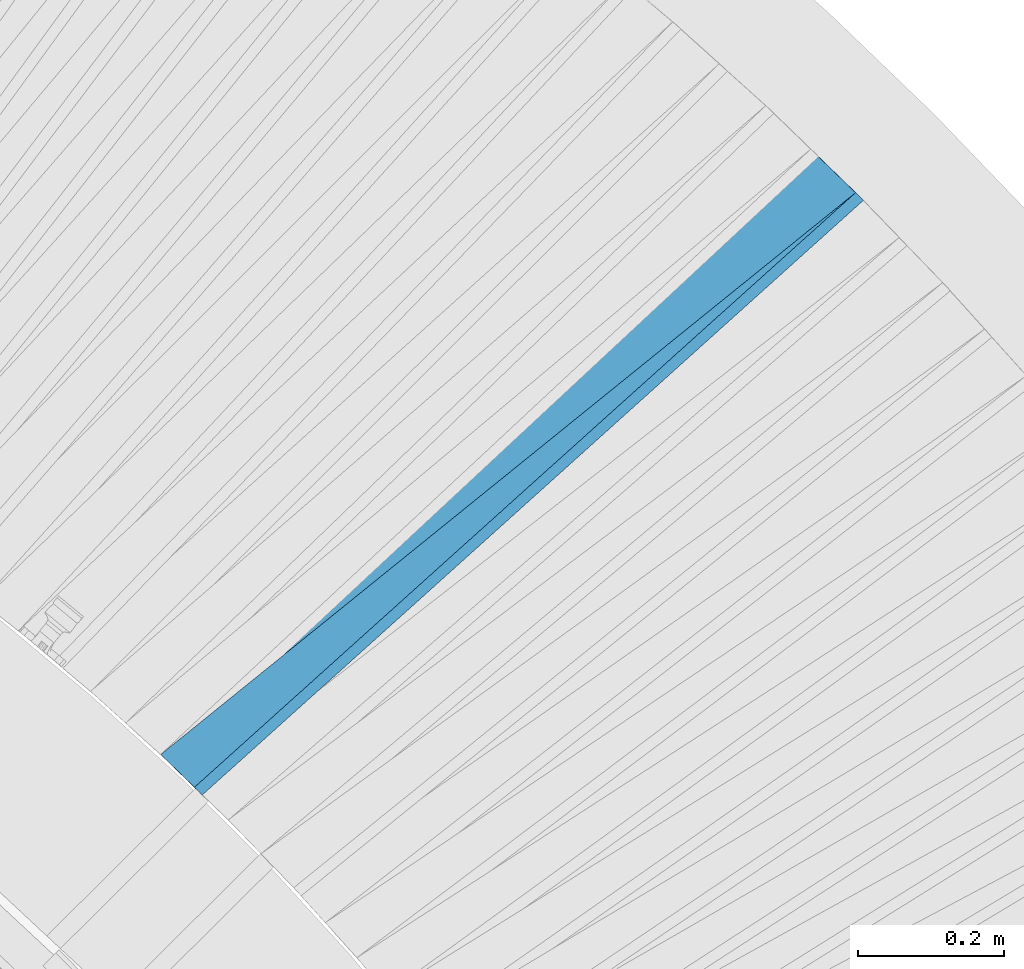
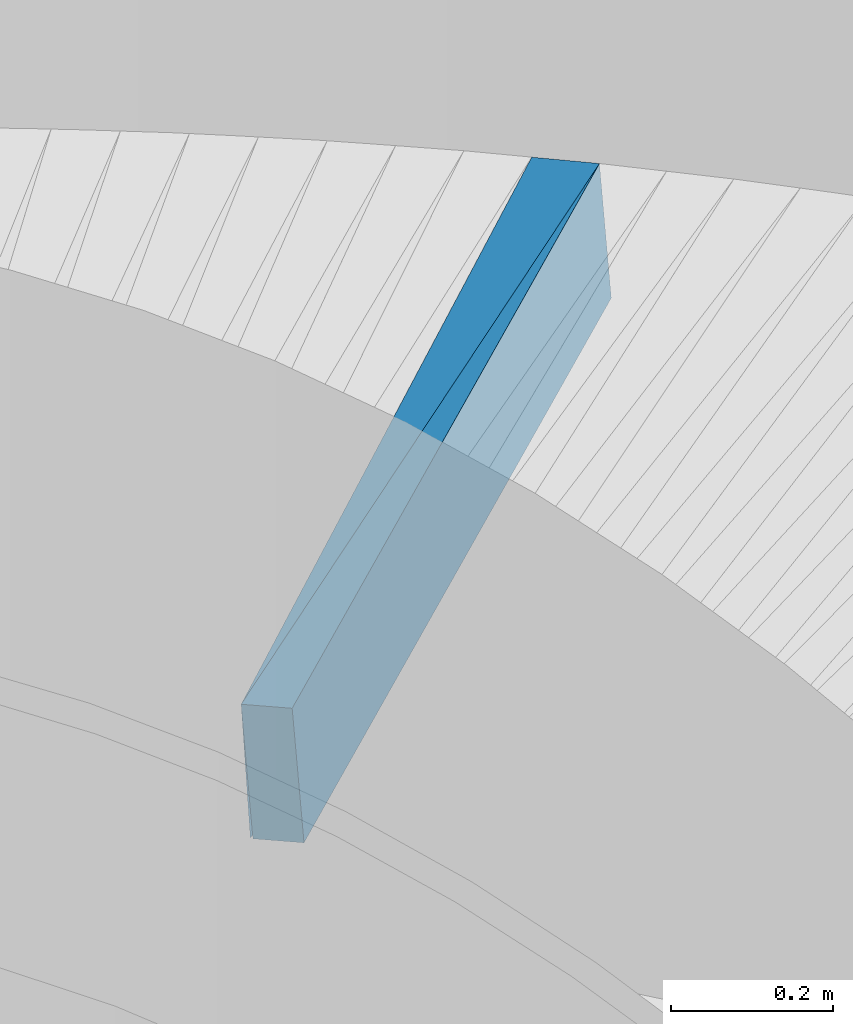
# One storey, part 841 of 975: 2 plates.
"""IFC2X3 building model written with IfcOpenShell, lengths in millimetres."""

from ifc_helpers import new_model, si_unit, frame, origin_with_axes, place, context, subcontext, project, spatial, faceted_brep, material, type_object, element, save


model = new_model("IFC2X3")

# Units and contexts
model_context = context("Model", 3, precision=1e-05, world=origin_with_axes())
body_context = subcontext(model_context, "Body", "Model", "MODEL_VIEW")
ifc_project = project(units=[si_unit("LENGTHUNIT", "METRE", prefix="MILLI"), si_unit("AREAUNIT", "SQUARE_METRE"), si_unit("VOLUMEUNIT", "CUBIC_METRE"), si_unit("MASSUNIT", "GRAM", prefix="KILO"), si_unit("TIMEUNIT", "SECOND"), si_unit("PLANEANGLEUNIT", "RADIAN"), si_unit("SOLIDANGLEUNIT", "STERADIAN"), si_unit("THERMODYNAMICTEMPERATUREUNIT", "DEGREE_CELSIUS"), si_unit("LUMINOUSINTENSITYUNIT", "LUMEN")], contexts=[model_context])

# Site, building, storey
site_placement = place(None, origin_with_axes())
site = spatial("IfcSite", under=ifc_project, at=site_placement, CompositionType="ELEMENT")
building_placement = place(site_placement, origin_with_axes())
building = spatial("IfcBuilding", under=site, at=building_placement, Name="Undefined", CompositionType="ELEMENT")
storey_placement = place(building_placement, origin_with_axes())
storey = spatial("IfcBuildingStorey", under=building, at=storey_placement, Name="Undefined", CompositionType="ELEMENT", Elevation=0.0)

# Plates
ifc_material = material(Name="STEEL/A36")
plate_type_1 = type_object("IfcPlateType", PredefinedType="NOTDEFINED")
plate_1_placement = place(storey_placement, frame((38161.2491672131, 6943.64217591275, 232.490790321188), z_axis=(0.680152573105857, -0.73077570815842, 0.0579598280107971), x_axis=(-0.731841587689349, -0.681462969710731, -0.00401390599829616)))
element("IfcPlate", 1, at=plate_1_placement, inside=storey, type_object=plate_type_1, material=ifc_material, Name="SLAB", context=body_context, shape_type="Brep", body=[
    faceted_brep([(-6.82121026329696e-12, -100.000000000011, -1.09139364212751e-10), (-4.56454038641095, -99.9999999999905, 85.9505386354322), (-4.56454038606898, 99.9999999999875, 85.9505386350502), (5.91171556152403e-12, 100.000000000011, 1.09139364212751e-10), (1220.75598144561, -99.9999999998736, 1.56433088704944e-09), (1220.75598144562, 100.000000000141, 1.74622982740402e-09)], [[[0, 1, 2, 3]], [[1, 4, 5, 2]], [[4, 0, 3, 5]], [[5, 3, 2]], [[4, 1, 0]]]),
])
plate_type_2 = type_object("IfcPlateType", PredefinedType="NOTDEFINED")
plate_2_placement = place(storey_placement, frame((38224.1464868164, 6882.58332052111, 237.606795995501), z_axis=(0.626437168463045, -0.775855096787258, 0.0750022850134328), x_axis=(-0.777640336801435, -0.628657734839477, -0.00805971499794202)))
element("IfcPlate", 2, at=plate_2_placement, inside=storey, type_object=plate_type_2, material=ifc_material, Name="SLAB", context=body_context, shape_type="Brep", body=[
    faceted_brep([(-6.82121026329696e-12, -100.000000000011, -1.09139364212751e-10), (1220.34338379136, -100.000000000173, 64.4729614234857), (1220.34338379146, 99.9999999998151, 64.4729614233802), (5.91171556152403e-12, 100.000000000011, 1.09139364212751e-10), (1228.33129883061, -100.000000000187, -2.04454408958554e-09), (1228.33129883072, 99.9999999998015, -2.1500454749912e-09)], [[[0, 1, 2, 3]], [[1, 4, 5, 2]], [[4, 0, 3, 5]], [[5, 3, 2]], [[4, 1, 0]]]),
])

save(model, "model.ifc")
